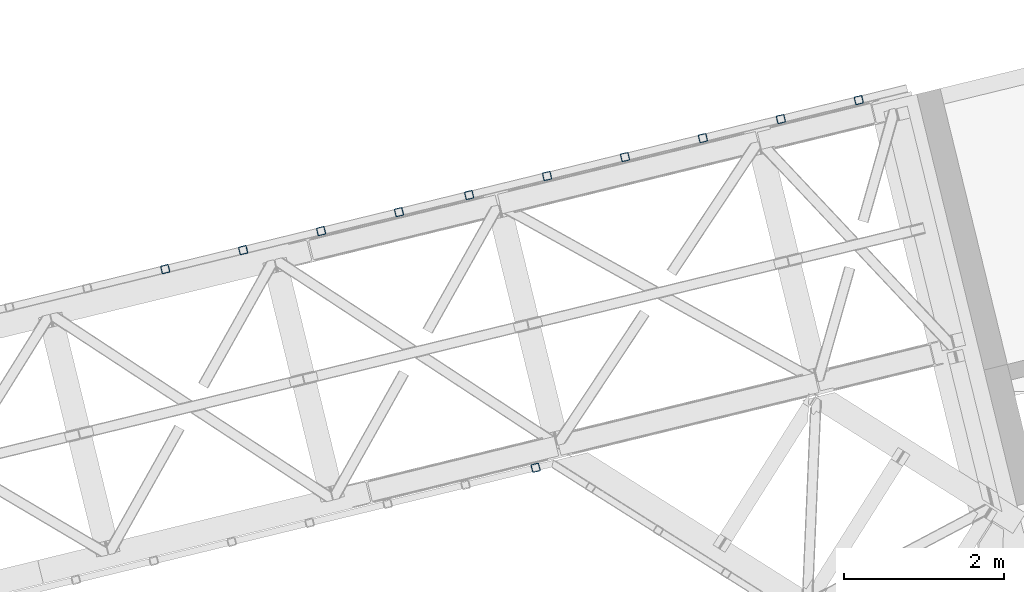
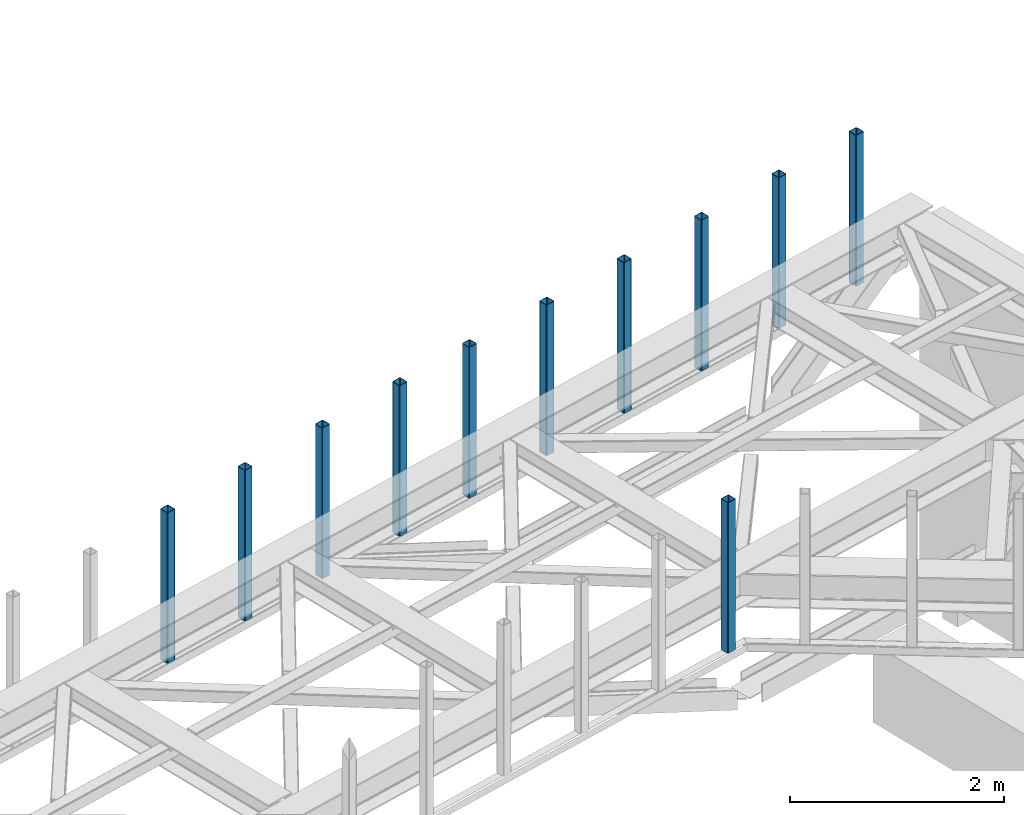
# One storey, part 11 of 67: 11 columns.
"""IFC4 building model written with IfcOpenShell, lengths in millimetres."""

from ifc_helpers import new_model, entity, si_unit, converted_unit, derived_unit, direction, frame, origin, place, context, subcontext, project, spatial, indexed_curve, outline, extrude, type_object, element, save


model = new_model("IFC4")

# Units and contexts
model_context = context("Model", 3, precision=0.01, world=origin(), true_north=direction((6.12303176911189e-17, 1.0)))
plan_context = context("Plan", 3, precision=0.01, world=origin(), true_north=direction((6.12303176911189e-17, 1.0)))
body_context = subcontext(model_context, "Body", "Model", "MODEL_VIEW")
ifc_project = project(units=[si_unit("LENGTHUNIT", "METRE", prefix="MILLI"), si_unit("AREAUNIT", "SQUARE_METRE"), si_unit("VOLUMEUNIT", "CUBIC_METRE"), converted_unit("PLANEANGLEUNIT", "DEGREE", entity("IfcRatioMeasure", 0.0174532925199433), si_unit("PLANEANGLEUNIT", "RADIAN"), dimensions=[0, 0, 0, 0, 0, 0, 0]), si_unit("MASSUNIT", "GRAM", prefix="KILO"), derived_unit("MASSDENSITYUNIT", [(si_unit("MASSUNIT", "GRAM", prefix="KILO"), 1), (si_unit("LENGTHUNIT", "METRE"), -3)]), derived_unit("MOMENTOFINERTIAUNIT", [(si_unit("LENGTHUNIT", "METRE"), 4)]), si_unit("TIMEUNIT", "SECOND"), si_unit("FREQUENCYUNIT", "HERTZ"), si_unit("THERMODYNAMICTEMPERATUREUNIT", "DEGREE_CELSIUS"), derived_unit("THERMALTRANSMITTANCEUNIT", [(si_unit("MASSUNIT", "GRAM", prefix="KILO"), 1), (si_unit("THERMODYNAMICTEMPERATUREUNIT", "KELVIN"), -1), (si_unit("TIMEUNIT", "SECOND"), -3)]), derived_unit("VOLUMETRICFLOWRATEUNIT", [(si_unit("LENGTHUNIT", "METRE"), 3), (si_unit("TIMEUNIT", "SECOND"), -1)]), derived_unit("MASSFLOWRATEUNIT", [(si_unit("MASSUNIT", "GRAM", prefix="KILO"), 1), (si_unit("TIMEUNIT", "SECOND"), -1)]), derived_unit("ROTATIONALFREQUENCYUNIT", [(si_unit("TIMEUNIT", "SECOND"), -1)]), si_unit("ELECTRICCURRENTUNIT", "AMPERE"), si_unit("ELECTRICVOLTAGEUNIT", "VOLT"), si_unit("POWERUNIT", "WATT"), si_unit("FORCEUNIT", "NEWTON", prefix="KILO"), si_unit("ILLUMINANCEUNIT", "LUX"), si_unit("LUMINOUSFLUXUNIT", "LUMEN"), si_unit("LUMINOUSINTENSITYUNIT", "CANDELA"), derived_unit("USERDEFINED", [(si_unit("MASSUNIT", "GRAM", prefix="KILO"), -1), (si_unit("LENGTHUNIT", "METRE"), -2), (si_unit("TIMEUNIT", "SECOND"), 3), (si_unit("LUMINOUSFLUXUNIT", "LUMEN"), 1)]), derived_unit("LINEARVELOCITYUNIT", [(si_unit("LENGTHUNIT", "METRE"), 1), (si_unit("TIMEUNIT", "SECOND"), -1)]), si_unit("PRESSUREUNIT", "PASCAL"), derived_unit("USERDEFINED", [(si_unit("LENGTHUNIT", "METRE"), -2), (si_unit("MASSUNIT", "GRAM", prefix="KILO"), 1), (si_unit("TIMEUNIT", "SECOND"), -2)]), derived_unit("LINEARFORCEUNIT", [(si_unit("MASSUNIT", "GRAM", prefix="KILO"), 1), (si_unit("LENGTHUNIT", "METRE"), 1), (si_unit("TIMEUNIT", "SECOND"), -2), (si_unit("LENGTHUNIT", "METRE"), -1)]), derived_unit("PLANARFORCEUNIT", [(si_unit("MASSUNIT", "GRAM", prefix="KILO"), 1), (si_unit("LENGTHUNIT", "METRE"), 1), (si_unit("TIMEUNIT", "SECOND"), -2), (si_unit("LENGTHUNIT", "METRE"), -2)])], contexts=[model_context, plan_context])

# Site, building, storey
site_placement = place(None, origin())
site = spatial("IfcSite", under=ifc_project, at=site_placement, CompositionType="ELEMENT")
building_placement = place(site_placement, origin())
building = spatial("IfcBuilding", under=site, at=building_placement, CompositionType="ELEMENT")
storey_placement = place(building_placement, frame((0.0, 0.0, 19800.0)))
storey = spatial("IfcBuildingStorey", under=building, at=storey_placement, CompositionType="ELEMENT", Elevation=19800.0)

# Columns
column_type_1 = type_object("IfcColumnType", PredefinedType="COLUMN")
column_1_placement = place(storey_placement, origin())
element("IfcColumn", 1, at=column_1_placement, inside=storey, type_object=column_type_1, ObjectType="Steel Column", PredefinedType="COLUMN", context=body_context, shape_type="SweptSolid", body=[
    extrude(outline(indexed_curve([(29.4768951153438, -56.8428769007969), (33.3787015556646, -56.8428769007969), (36.9835006656957, -55.3497202197868), (39.742494458526, -52.5907264269608), (41.235651139533, -48.9859273169217), (56.8428769007998, 29.476895115338), (56.8428769007996, 33.3787015556615), (55.3497202197897, 36.9835006656988), (52.5907264269624, 39.7424944585244), (48.9859273169288, 41.2356511395317), (-29.476895115342, 56.8428769008008), (-33.3787015556628, 56.8428769008008), (-36.9835006657015, 55.3497202197943), (-39.7424944585166, 52.5907264269612), (-41.2356511395312, 48.9859273169256), (-56.8428769007996, -29.4768951153381), (-56.84287690079, -33.3787015556612), (-55.3497202197955, -36.9835006656913), (-52.5907264269606, -39.7424944585204), (-48.985927316927, -41.2356511395278), (29.4768951153438, -56.8428769007969)], self_intersect=False), holes=[indexed_curve([(-43.1065493048248, -37.3071763475937), (-46.7113484148532, -35.8140196665887), (-49.4703422076904, -33.0550258737586), (-50.9634988886897, -29.4502267637262), (-50.9634988886947, -25.5484203234053), (-37.3071763475804, 43.106549304824), (-35.8140196665827, 46.7113484148579), (-33.0550258737537, 49.470342207694), (-29.4502267637163, 50.9634988886964), (-25.5484203233976, 50.9634988887022), (43.1065493048361, 37.3071763475885), (46.7113484148689, 35.8140196665814), (49.4703422076964, 33.0550258737511), (50.963498888715, 29.450226763724), (50.9634988887109, 25.5484203233977), (37.3071763475966, -43.1065493048315), (35.8140196665955, -46.7113484148734), (33.0550258737621, -49.4703422076932), (29.4502267637325, -50.963498888704), (25.5484203234073, -50.9634988887019), (-43.1065493048248, -37.3071763475937)], self_intersect=False)]), frame((-1656.4770818766, 20594.4202484961, 3378.0), z_axis=(0.0, 0.0, 1.0), x_axis=(0.906681479027433, 0.421815949898326, 0.0)), (0.0, 0.0, 1.0), 1720.00000000001),
])
column_type_2 = type_object("IfcColumnType", PredefinedType="COLUMN")
column_2_placement = place(storey_placement, origin())
element("IfcColumn", 2, at=column_2_placement, inside=storey, type_object=column_type_2, ObjectType="Steel Column", PredefinedType="COLUMN", context=body_context, shape_type="SweptSolid", body=[
    extrude(outline(indexed_curve([(29.4768951153443, -56.8428769007955), (33.3787015556653, -56.8428769007955), (36.983500665704, -55.3497202197888), (39.7424944585282, -52.5907264269551), (41.2356511395332, -48.9859273169199), (56.8428769007977, 29.4768951153402), (56.8428769007972, 33.3787015556638), (55.3497202197953, 36.9835006656973), (52.5907264269598, 39.7424944585266), (48.9859273169262, 41.2356511395338), (-29.4768951153449, 56.8428769008005), (-33.3787015556659, 56.8428769008005), (-36.9835006656967, 55.3497202197902), (-39.7424944585288, 52.5907264269602), (-41.2356511395338, 48.985927316925), (-56.8428769008002, -29.4768951153391), (-56.8428769007996, -33.3787015556627), (-55.349720219788, -36.9835006656959), (-52.5907264269604, -39.7424944585215), (-48.9859273169273, -41.2356511395285), (29.4768951153443, -56.8428769007955)], self_intersect=False), holes=[indexed_curve([(-43.1065493048252, -37.3071763475943), (-46.7113484148636, -35.8140196665896), (-49.4703422076951, -33.0550258737479), (-50.9634988886977, -29.4502267637236), (-50.9634988887035, -25.5484203234023), (-37.3071763475993, 43.1065493048311), (-35.814019666589, 46.7113484148687), (-33.0550258737723, 49.4703422076915), (-29.4502267637273, 50.9634988887), (-25.5484203234006, 50.9634988887021), (43.1065493048173, 37.307176347598), (46.7113484148541, 35.8140196665988), (49.4703422076856, 33.0550258737571), (50.9634988886948, 29.450226763725), (50.9634988887006, 25.5484203234037), (37.3071763475946, -43.1065493048337), (35.8140196665904, -46.7113484148645), (33.0550258737537, -49.4703422076876), (29.4502267637152, -50.9634988886992), (25.5484203233981, -50.963498888701), (-43.1065493048252, -37.3071763475943)], self_intersect=False)]), frame((-2628.02914001807, 20357.5941555058, 3378.0), z_axis=(0.0, 0.0, 1.0), x_axis=(0.906681479027445, 0.4218159498983, 0.0)), (0.0, 0.0, 1.0), 1720.00000000001),
])
column_type_3 = type_object("IfcColumnType", PredefinedType="COLUMN")
column_3_placement = place(storey_placement, origin())
element("IfcColumn", 3, at=column_3_placement, inside=storey, type_object=column_type_3, ObjectType="Steel Column", PredefinedType="COLUMN", context=body_context, shape_type="SweptSolid", body=[
    extrude(outline(indexed_curve([(29.4768951152834, -56.842876900833), (33.3787015556062, -56.842876900833), (36.9835006656294, -55.3497202198268), (39.7424944584721, -52.5907264270032), (41.2356511394807, -48.9859273169695), (56.8428769008256, 29.4768951152791), (56.8428769008295, 33.3787015556025), (55.3497202198136, 36.9835006656409), (52.5907264269984, 39.7424944584695), (48.9859273169645, 41.2356511394765), (-29.4768951152816, 56.8428769008226), (-33.3787015556026, 56.8428769008265), (-36.983500665652, 55.349720219823), (-39.7424944584698, 52.5907264269926), (-41.2356511394877, 48.9859273169583), (-56.8428769008312, -29.476895115286), (-56.8428769008272, -33.3787015556131), (-55.3497202198363, -36.9835006656447), (-52.5907264269944, -39.7424944584762), (-48.9859273169628, -41.2356511394868), (29.4768951152834, -56.842876900833)], self_intersect=False), holes=[indexed_curve([(-43.1065493048641, -37.3071763475551), (-46.711348414901, -35.8140196665468), (-49.470342207726, -33.0550258737136), (-50.9634988887297, -29.450226763676), (-50.9634988887227, -25.5484203233588), (-37.3071763475573, 43.1065493048645), (-35.8140196665383, 46.7113484148934), (-33.0550258737162, 49.4703422077266), (-29.4502267636774, 50.9634988887255), (-25.5484203233506, 50.9634988887237), (43.1065493048536, 37.3071763475504), (46.711348414896, 35.814019666549), (49.4703422077232, 33.0550258737101), (50.9634988887331, 29.4502267636744), (50.963498888725, 25.5484203233482), (37.3071763475433, -43.1065493048675), (35.8140196665392, -46.7113484149082), (33.0550258737026, -49.470342207725), (29.4502267636626, -50.9634988887329), (25.5484203233455, -50.9634988887308), (-43.1065493048641, -37.3071763475551)], self_intersect=False)]), frame((-3599.58119815953, 20120.7680625154, 3378.0), z_axis=(0.0, 0.0, 1.0), x_axis=(0.90668147902702, 0.421815949899212, 0.0)), (0.0, 0.0, 1.0), 1720.00000000001),
])
column_type_4 = type_object("IfcColumnType", PredefinedType="COLUMN")
column_4_placement = place(storey_placement, origin())
element("IfcColumn", 4, at=column_4_placement, inside=storey, type_object=column_type_4, ObjectType="Steel Column", PredefinedType="COLUMN", context=body_context, shape_type="SweptSolid", body=[
    extrude(outline(indexed_curve([(29.4768951153332, -56.8428769007999), (33.3787015556542, -56.8428769007999), (36.9835006657021, -55.3497202197927), (39.7424944585171, -52.5907264269596), (41.23565113953, -48.985927316928), (56.8428769007959, 29.4768951153363), (56.8428769007862, 33.3787015556594), (55.3497202197934, 36.9835006656934), (52.5907264269487, 39.7424944585222), (48.9859273169151, 41.2356511395294), (-29.4768951153389, 56.842876900793), (-33.3787015556599, 56.842876900793), (-36.9835006656907, 55.3497202197826), (-39.7424944585301, 52.590726426956), (-41.2356511395278, 48.9859273169174), (-56.8428769007942, -29.4768951153466), (-56.8428769008015, -33.3787015556666), (-55.349720219782, -36.9835006657035), (-52.5907264269544, -39.7424944585291), (-48.9859273169212, -41.2356511395361), (29.4768951153332, -56.8428769007999)], self_intersect=False), holes=[indexed_curve([(-43.1065493048265, -37.3071763475985), (-46.7113484148607, -35.8140196666053), (-49.4703422076881, -33.0550258737702), (-50.9634988886994, -29.4502267637324), (-50.963498888697, -25.5484203234101), (-37.3071763475863, 43.1065493048155), (-35.8140196665868, 46.7113484148581), (-33.0550258737512, 49.4703422076817), (-29.4502267637208, 50.9634988886922), (-25.5484203234024, 50.9634988886982), (43.1065493048304, 37.3071763475823), (46.7113484148666, 35.8140196665834), (49.4703422076925, 33.0550258737539), (50.9634988887013, 29.4502267637172), (50.9634988886992, 25.5484203233995), (37.307176347595, -43.1065493048339), (35.8140196665866, -46.7113484148675), (33.05502587376, -49.4703422077049), (29.4502267637291, -50.9634988887104), (25.5484203234041, -50.9634988887086), (-43.1065493048265, -37.3071763475985)], self_intersect=False)]), frame((-4571.13325630104, 19883.9419695251, 3378.0), z_axis=(0.0, 0.0, 1.0), x_axis=(0.906681479027445, 0.4218159498983, 0.0)), (0.0, 0.0, 1.0), 1720.00000000001),
])
column_type_5 = type_object("IfcColumnType", PredefinedType="COLUMN")
column_5_placement = place(storey_placement, origin())
element("IfcColumn", 5, at=column_5_placement, inside=storey, type_object=column_type_5, ObjectType="Steel Column", PredefinedType="COLUMN", context=body_context, shape_type="SweptSolid", body=[
    extrude(outline(indexed_curve([(29.4768951153379, -56.8428769007925), (33.3787015556589, -56.8428769007925), (36.9835006656981, -55.349720219786), (39.7424944585296, -52.5907264269558), (41.2356511395273, -48.9859273169171), (56.8428769007914, 29.4768951153432), (56.842876900801, 33.3787015556669), (55.3497202197894, 36.9835006657001), (52.5907264269544, 39.7424944585291), (48.9859273169203, 41.2356511395366), (-29.4768951153342, 56.8428769008003), (-33.3787015556542, 56.8428769007999), (-36.9835006656934, 55.3497202197934), (-39.7424944585171, 52.5907264269595), (-41.2356511395305, 48.9859273169282), (-56.8428769007964, -29.476895115336), (-56.8428769007885, -33.3787015556631), (-55.3497202197847, -36.9835006656927), (-52.5907264269497, -39.7424944585217), (-48.9859273169156, -41.2356511395292), (29.4768951153379, -56.8428769007925)], self_intersect=False), holes=[indexed_curve([(-43.1065493048293, -37.3071763475876), (-46.7113484148548, -35.8140196665746), (-49.4703422076866, -33.0550258737566), (-50.9634988886944, -29.4502267637204), (-50.9634988886905, -25.5484203233988), (-37.3071763475803, 43.106549304827), (-35.8140196665784, 46.7113484148542), (-33.0550258737519, 49.4703422076916), (-29.4502267637225, 50.9634988887026), (-25.5484203234065, 50.9634988887049), (43.1065493048387, 37.3071763475976), (46.7113484148736, 35.8140196665945), (49.4703422077027, 33.0550258737682), (50.9634988887155, 29.4502267637297), (50.9634988887136, 25.5484203234072), (37.3071763475997, -43.1065493048265), (35.8140196665941, -46.7113484148615), (33.0550258737577, -49.4703422076895), (29.4502267637378, -50.9634988886954), (25.5484203234111, -50.9634988886975), (-43.1065493048293, -37.3071763475876)], self_intersect=False)]), frame((-5542.68531444249, 19647.1158765348, 3378.0), z_axis=(0.0, 0.0, 1.0), x_axis=(0.906681479027445, 0.4218159498983, 0.0)), (0.0, 0.0, 1.0), 1720.00000000001),
])
column_type_6 = type_object("IfcColumnType", PredefinedType="COLUMN")
column_6_placement = place(storey_placement, origin())
element("IfcColumn", 6, at=column_6_placement, inside=storey, type_object=column_type_6, ObjectType="Steel Column", PredefinedType="COLUMN", context=body_context, shape_type="SweptSolid", body=[
    extrude(outline(indexed_curve([(29.476895115345, -56.8428769008029), (33.378701555666, -56.8428769008029), (36.9835006656885, -55.3497202197912), (39.7424944585289, -52.590726426965), (41.2356511395335, -48.9859273169296), (56.8428769008003, 29.4768951153342), (56.8428769007993, 33.3787015556581), (55.3497202197789, 36.983500665693), (52.5907264269614, 39.7424944585186), (48.9859273169273, 41.2356511395261), (-29.4768951153437, 56.8428769007928), (-33.3787015556656, 56.8428769007908), (-36.983500665696, 55.3497202197827), (-39.7424944585276, 52.5907264269525), (-41.2356511395409, 48.9859273169187), (-56.8428769008078, -29.4768951153451), (-56.842876900798, -33.3787015556682), (-55.3497202197864, -36.9835006657039), (-52.5907264269601, -39.7424944585312), (-48.9859273169261, -41.2356511395363), (29.476895115345, -56.8428769008029)], self_intersect=False), holes=[indexed_curve([(-43.106549304823, -37.3071763476025), (-46.71134841486, -35.814019666596), (-49.4703422076915, -33.0550258737543), (-50.9634988886951, -29.4502267637296), (-50.9634988887009, -25.5484203234083), (-37.3071763475967, 43.1065493048251), (-35.8140196665883, 46.7113484148588), (-33.0550258737691, 49.4703422076828), (-29.4502267637233, 50.9634988886958), (-25.5484203233984, 50.9634988886939), (43.1065493048204, 37.3071763475917), (46.7113484148563, 35.8140196665906), (49.4703422076896, 33.0550258737528), (50.9634988886973, 29.450226763719), (50.9634988887041, 25.5484203233997), (37.3071763475981, -43.1065493048377), (35.8140196665925, -46.7113484148727), (33.0550258737568, -49.4703422076938), (29.4502267637188, -50.9634988887056), (25.5484203234007, -50.963498888707), (-43.106549304823, -37.3071763476025)], self_intersect=False)]), frame((-6514.23737258396, 19410.2897835444, 3378.0), z_axis=(0.0, 0.0, 1.0), x_axis=(0.906681479027445, 0.4218159498983, 0.0)), (0.0, 0.0, 1.0), 1720.00000000001),
])
column_type_7 = type_object("IfcColumnType", PredefinedType="COLUMN")
column_7_placement = place(storey_placement, origin())
element("IfcColumn", 7, at=column_7_placement, inside=storey, type_object=column_type_7, ObjectType="Steel Column", PredefinedType="COLUMN", context=body_context, shape_type="SweptSolid", body=[
    extrude(outline(indexed_curve([(29.4768951153447, -56.8428769007933), (33.3787015556657, -56.8428769007933), (36.9835006657039, -55.3497202197863), (39.7424944585189, -52.5907264269532), (41.2356511395322, -48.9859273169194), (56.8428769007991, 29.4768951153444), (56.8428769007903, 33.3787015556695), (55.3497202197952, 36.9835006656998), (52.5907264269602, 39.7424944585288), (48.9859273169261, 41.2356511395363), (-29.4768951153362, 56.8428769008012), (-33.3787015556581, 56.8428769007993), (-36.9835006656963, 55.3497202197924), (-39.7424944585289, 52.5907264269626), (-41.2356511395246, 48.9859273169254), (-56.8428769007915, -29.4768951153384), (-56.8428769007983, -33.3787015556586), (-55.3497202197876, -36.9835006656938), (-52.5907264269526, -39.7424944585228), (-48.9859273169186, -41.2356511395278), (29.4768951153447, -56.8428769007933)], self_intersect=False), holes=[indexed_curve([(-43.106549304833, -37.3071763475907), (-46.7113484148615, -35.8140196665787), (-49.4703422076866, -33.0550258737542), (-50.963498888706, -29.4502267637222), (-50.9634988887031, -25.5484203234001), (-37.307176347591, 43.1065493048296), (-35.8140196665906, 46.7113484148718), (-33.0550258737549, 49.4703422076953), (-29.4502267637333, 50.9634988887052), (-25.5484203234075, 50.9634988887077), (43.1065493048279, 37.3071763476002), (46.7113484148602, 35.8140196665888), (49.470342207697, 33.0550258737661), (50.9634988886961, 29.4502267637292), (50.9634988887019, 25.5484203234078), (37.3071763475908, -43.10654930482), (35.8140196665883, -46.7113484148612), (33.055025873754, -49.4703422076949), (29.4502267637253, -50.9634988886967), (25.5484203234082, -50.9634988886985), (-43.106549304833, -37.3071763475907)], self_intersect=False)]), frame((-7388.63422491131, 19197.1462998531, 3378.0), z_axis=(0.0, 0.0, 1.0), x_axis=(0.906681479027445, 0.4218159498983, 0.0)), (0.0, 0.0, 1.0), 1720.00000000001),
])
column_type_8 = type_object("IfcColumnType", PredefinedType="COLUMN")
column_8_placement = place(storey_placement, origin())
element("IfcColumn", 8, at=column_8_placement, inside=storey, type_object=column_type_8, ObjectType="Steel Column", PredefinedType="COLUMN", context=body_context, shape_type="SweptSolid", body=[
    extrude(outline(indexed_curve([(29.4768951153362, -56.8428769008012), (33.3787015556572, -56.8428769008012), (36.9835006656963, -55.3497202197924), (39.7424944585279, -52.5907264269646), (41.2356511395247, -48.9859273169279), (56.8428769007906, 29.4768951153364), (56.8428769007983, 33.3787015556586), (55.3497202197867, 36.9835006656918), (52.5907264269526, 39.7424944585228), (48.9859273169186, 41.2356511395278), (-29.4768951153359, 56.8428769007916), (-33.3787015556578, 56.8428769007896), (-36.9835006657048, 55.3497202197844), (-39.7424944585198, 52.5907264269512), (-41.2356511395331, 48.9859273169175), (-56.8428769008, -29.4768951153463), (-56.8428769007903, -33.3787015556695), (-55.3497202197961, -36.9835006657017), (-52.5907264269523, -39.7424944585324), (-48.9859273169183, -41.2356511395375), (29.4768951153362, -56.8428769008012)], self_intersect=False), holes=[indexed_curve([(-43.1065493048328, -37.3071763476003), (-46.7113484148662, -35.8140196665836), (-49.4703422076883, -33.0550258737654), (-50.9634988886978, -29.4502267637355), (-50.963498888694, -25.5484203234115), (-37.3071763475838, 43.1065493048144), (-35.8140196665864, 46.7113484148603), (-33.0550258737616, 49.4703422076913), (-29.450226763733, 50.9634988886955), (-25.5484203234081, 50.9634988886961), (43.1065493048282, 37.3071763475905), (46.7113484148701, 35.8140196665818), (49.4703422076932, 33.0550258737631), (50.9634988887051, 29.4502267637202), (50.9634988887031, 25.5484203234001), (37.307176347591, -43.1065493048296), (35.8140196665894, -46.7113484148641), (33.0550258737542, -49.4703422077022), (29.4502267637256, -50.9634988887064), (25.5484203234085, -50.9634988887082), (-43.1065493048328, -37.3071763476003)], self_intersect=False)]), frame((-8360.18628305276, 18960.3202068628, 3378.0), z_axis=(0.0, 0.0, 1.0), x_axis=(0.906681479027445, 0.4218159498983, 0.0)), (0.0, 0.0, 1.0), 1720.00000000001),
])
column_type_9 = type_object("IfcColumnType", PredefinedType="COLUMN")
column_9_placement = place(storey_placement, origin())
element("IfcColumn", 9, at=column_9_placement, inside=storey, type_object=column_type_9, ObjectType="Steel Column", PredefinedType="COLUMN", context=body_context, shape_type="SweptSolid", body=[
    extrude(outline(indexed_curve([(29.4768951153467, -56.8428769007942), (33.3787015556676, -56.8428769007942), (36.9835006656902, -55.3497202197824), (39.7424944585209, -52.5907264269541), (41.2356511395352, -48.9859273169208), (56.842876900801, 29.4768951153434), (56.8428769007922, 33.3787015556685), (55.3497202197806, 36.9835006657018), (52.5907264269631, 39.7424944585298), (48.985927316929, 41.2356511395349), (-29.476895115343, 56.842876900802), (-33.3787015556639, 56.8428769007996), (-36.9835006656943, 55.3497202197915), (-39.7424944585181, 52.59072642696), (-41.2356511395314, 48.9859273169262), (-56.8428769007964, -29.476895115336), (-56.8428769007876, -33.3787015556612), (-55.3497202197856, -36.9835006656947), (-52.5907264269594, -39.742494458522), (-48.9859273169244, -41.2356511395275), (29.4768951153467, -56.8428769007942)], self_intersect=False), holes=[indexed_curve([(-43.1065493048223, -37.3071763475933), (-46.7113484148514, -35.8140196665905), (-49.4703422076943, -33.0550258737578), (-50.9634988886962, -29.4502267637267), (-50.9634988886924, -25.5484203234027), (-37.3071763475882, 43.1065493048307), (-35.8140196665797, 46.7113484148643), (-33.0550258737519, 49.4703422076916), (-29.4502267637139, 50.9634988887033), (-25.5484203233977, 50.9634988887032), (43.106549304829, 37.3071763475973), (46.7113484148657, 35.8140196665981), (49.4703422076903, 33.0550258737621), (50.9634988887068, 29.450226763729), (50.9634988887048, 25.5484203234089), (37.3071763475988, -43.1065493048285), (35.8140196665911, -46.7113484148553), (33.0550258737654, -49.4703422076883), (29.4502267637273, -50.9634988887), (25.5484203234014, -50.9634988886977), (-43.1065493048223, -37.3071763475933)], self_intersect=False)]), frame((-9331.73834119423, 18723.4941138724, 3378.0), z_axis=(0.0, 0.0, 1.0), x_axis=(0.906681479027445, 0.4218159498983, 0.0)), (0.0, 0.0, 1.0), 1720.00000000001),
])
column_type_10 = type_object("IfcColumnType", PredefinedType="COLUMN")
column_10_placement = place(storey_placement, origin())
element("IfcColumn", 10, at=column_10_placement, inside=storey, type_object=column_type_10, ObjectType="Steel Column", PredefinedType="COLUMN", context=body_context, shape_type="SweptSolid", body=[
    extrude(outline(indexed_curve([(29.4768951153351, -56.8428769007984), (33.3787015556561, -56.8428769007984), (36.9835006656943, -55.3497202197915), (39.7424944585259, -52.5907264269612), (41.2356511395227, -48.9859273169245), (56.8428769007886, 29.4768951153397), (56.8428769007982, 33.378701555661), (55.3497202197866, 36.9835006656942), (52.5907264269506, 39.7424944585237), (48.9859273169165, 41.2356511395312), (-29.476895115337, 56.8428769007944), (-33.3787015556589, 56.8428769007925), (-36.9835006656971, 55.3497202197856), (-39.7424944585218, 52.5907264269546), (-41.2356511395342, 48.9859273169203), (-56.8428769008001, -29.4768951153439), (-56.8428769007913, -33.3787015556666), (-55.3497202197894, -36.9835006657001), (-52.5907264269534, -39.7424944585296), (-48.9859273169203, -41.2356511395342), (29.4768951153351, -56.8428769007984)], self_intersect=False), holes=[indexed_curve([(-43.1065493048328, -37.3071763475979), (-46.7113484148583, -35.8140196665873), (-49.4703422076902, -33.0550258737645), (-50.9634988886981, -29.4502267637282), (-50.963498888695, -25.548420323411), (-37.3071763475848, 43.1065493048148), (-35.8140196665802, 46.7113484148478), (-33.0550258737556, 49.4703422076837), (-29.4502267637252, 50.9634988886943), (-25.5484203234092, 50.963498888699), (43.1065493048351, 37.3071763475873), (46.7113484148681, 35.8140196665827), (49.4703422077001, 33.0550258737599), (50.9634988887118, 29.4502267637219), (50.96349888871, 25.5484203233969), (37.3071763475969, -43.10654930483), (35.8140196665877, -46.7113484148728), (33.0550258737542, -49.4703422077021), (29.4502267637324, -50.9634988887096), (25.5484203234084, -50.9634988887058), (-43.1065493048328, -37.3071763475979)], self_intersect=False)]), frame((-10303.2903993357, 18486.6680208821, 3378.0), z_axis=(0.0, 0.0, 1.0), x_axis=(0.906681479027445, 0.4218159498983, 0.0)), (0.0, 0.0, 1.0), 1720.00000000001),
])
column_type_11 = type_object("IfcColumnType", PredefinedType="COLUMN")
column_11_placement = place(storey_placement, origin())
element("IfcColumn", 11, at=column_11_placement, inside=storey, type_object=column_type_11, ObjectType="Steel Column", PredefinedType="COLUMN", context=body_context, shape_type="SweptSolid", body=[
    extrude(outline(indexed_curve([(29.4768951153175, -56.8428769007893), (33.3787015556517, -56.8428769007893), (36.9835006656797, -55.3497202197804), (39.742494458509, -52.5907264269499), (41.2356511395092, -48.9859273169124), (56.8428769008095, 29.4768951153402), (56.8428769008059, 33.3787015556642), (55.3497202198135, 36.9835006656941), (52.5907264269757, 39.7424944585232), (48.9859273169434, 41.2356511395293), (-29.4768951153155, 56.8428769007884), (-33.3787015556488, 56.8428769007903), (-36.9835006656681, 55.3497202197797), (-39.7424944585071, 52.5907264269514), (-41.2356511395063, 48.9859273169134), (-56.8428769008067, -29.4768951153392), (-56.842876900803, -33.3787015556631), (-55.3497202198106, -36.983500665693), (-52.5907264269815, -39.7424944585204), (-48.9859273169405, -41.2356511395282), (29.4768951153175, -56.8428769007893)], self_intersect=False), holes=[indexed_curve([(-43.1065493048481, -37.307176347587), (-46.7113484148773, -35.8140196665895), (-49.4703422077104, -33.0550258737554), (-50.9634988887155, -29.450226763722), (-50.963498888721, -25.5484203233995), (-37.3071763475943, 43.10654930483), (-35.8140196665766, 46.7113484148641), (-33.0550258737414, 49.4703422076918), (-29.4502267637171, 50.9634988886953), (-25.5484203233908, 50.963498888699), (43.1065493048441, 37.3071763475912), (46.7113484148705, 35.8140196665903), (49.4703422077045, 33.0550258737558), (50.9634988887037, 29.4502267637275), (50.9634988887073, 25.548420323406), (37.3071763475824, -43.1065493048196), (35.8140196665705, -46.7113484148492), (33.0550258737373, -49.4703422076803), (29.4502267637121, -50.9634988886881), (25.5484203233868, -50.9634988886923), (-43.1065493048481, -37.307176347587)], self_intersect=False)]), frame((-5685.11084900596, 16009.749596746, 3378.00379513655), z_axis=(0.0, 0.0, 1.0), x_axis=(-0.904974271849281, -0.425466293953896, 0.0)), (0.0, 0.0, 1.0), 1719.99999999989),
])

save(model, "model.ifc")
